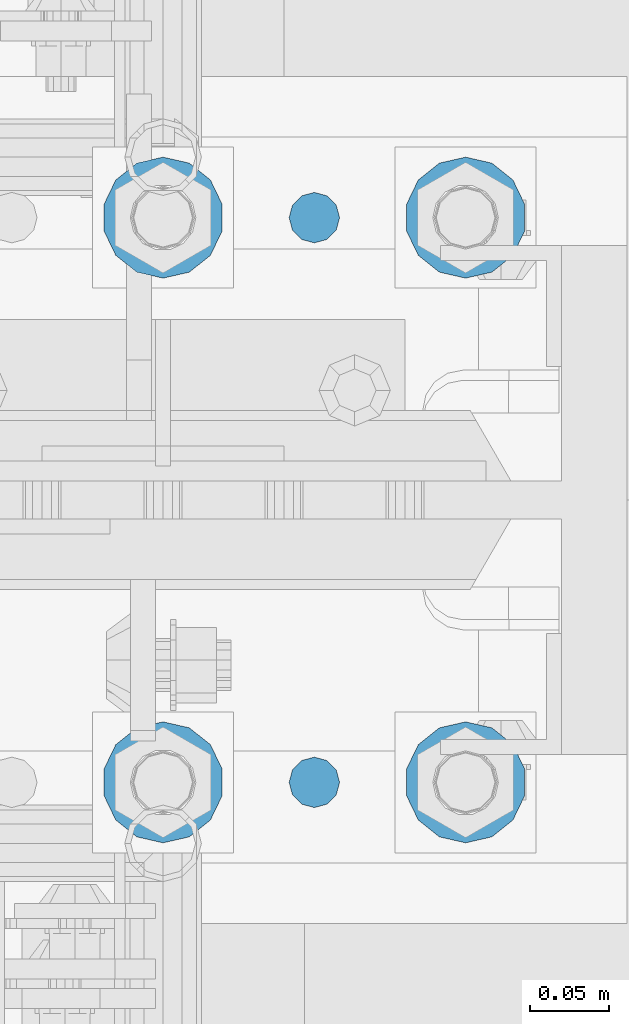
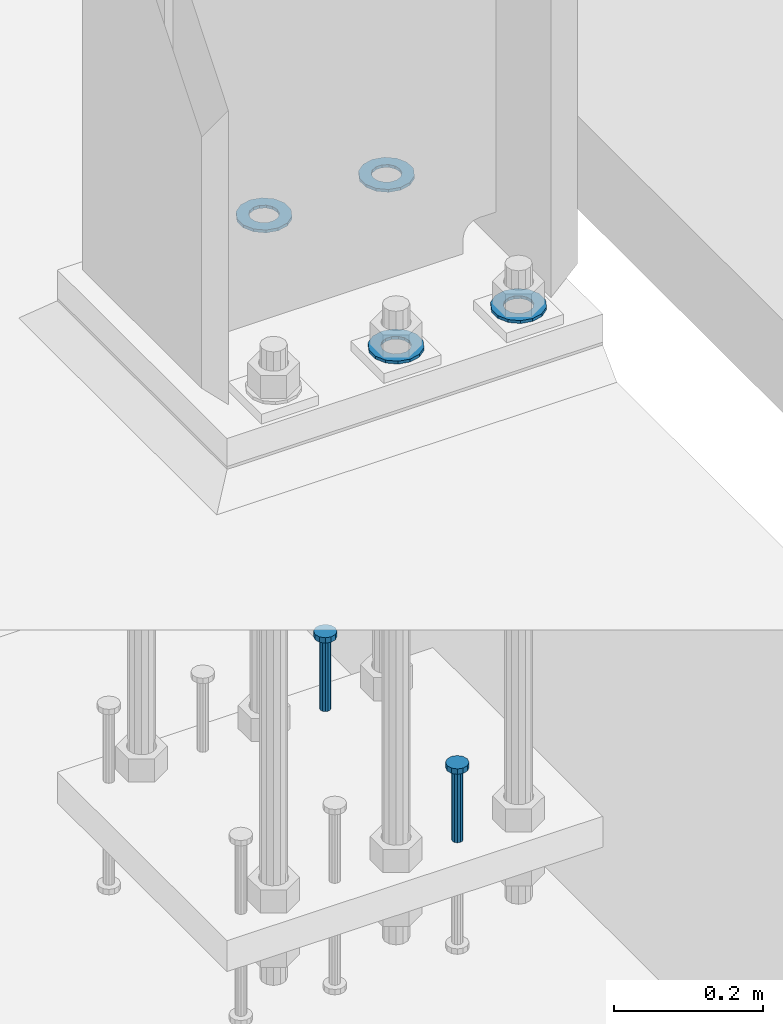
# One storey, part 832 of 1876: 6 columns, 1 element without a shape of its own.
"""IFC2X3 building model written with IfcOpenShell, lengths in millimetres."""

from ifc_helpers import new_model, si_unit, frame, origin_with_axes, place, context, subcontext, project, spatial, faceted_brep, material, type_object, element, aggregate, save


model = new_model("IFC2X3")

# Units and contexts
model_context = context("Model", 3, precision=1e-05, world=origin_with_axes())
body_context = subcontext(model_context, "Body", "Model", "MODEL_VIEW")
ifc_project = project(units=[si_unit("LENGTHUNIT", "METRE", prefix="MILLI"), si_unit("AREAUNIT", "SQUARE_METRE"), si_unit("VOLUMEUNIT", "CUBIC_METRE"), si_unit("MASSUNIT", "GRAM", prefix="KILO"), si_unit("TIMEUNIT", "SECOND"), si_unit("PLANEANGLEUNIT", "RADIAN"), si_unit("SOLIDANGLEUNIT", "STERADIAN"), si_unit("THERMODYNAMICTEMPERATUREUNIT", "DEGREE_CELSIUS"), si_unit("LUMINOUSINTENSITYUNIT", "LUMEN")], contexts=[model_context])

# Site, building, storey
site_placement = place(None, origin_with_axes())
site = spatial("IfcSite", under=ifc_project, at=site_placement, CompositionType="ELEMENT")
building_placement = place(site_placement, origin_with_axes())
building = spatial("IfcBuilding", under=site, at=building_placement, Name="Undefined", CompositionType="ELEMENT")
storey_placement = place(building_placement, origin_with_axes())
storey = spatial("IfcBuildingStorey", under=building, at=storey_placement, Name="Undefined", CompositionType="ELEMENT", Elevation=0.0)

# Assembly, columns
assembly_placement = place(storey_placement, origin_with_axes())
assembly = element("IfcElementAssembly", 1, at=assembly_placement, inside=storey, Name="TEMPLATE", AssemblyPlace="NOTDEFINED", PredefinedType="RIGID_FRAME")
ifc_material_1 = material(Name="STEEL/F436")
column_type_1 = type_object("IfcColumnType", Name="1-1/2_WASHER", PredefinedType="NOTDEFINED")
column_1_placement = place(assembly_placement, frame((7810.5, -4749.8, 109.5375), z_axis=(1.0, 0.0, 0.0), x_axis=(0.0, 0.0, -1.0)))
column_1 = element("IfcColumn", 2, at=column_1_placement, type_object=column_type_1, material=ifc_material_1, Name="WASHER", ObjectType="1-1/2_WASHER", context=body_context, shape_type="Brep", body=[
    faceted_brep([(0.0, -38.0999984741211, 0.0), (0.0, -34.3269124923136, -16.5309697983251), (4.7625, -34.3269124923136, -16.5309697983251), (4.7625, -38.0999984741211, 0.0), (0.0, -23.7549604994474, -29.787778289052), (4.7625, -23.7549604994474, -29.787778289052), (0.0, -8.4780472441962, -37.1447519665058), (4.7625, -8.4780472441962, -37.1447519665058), (0.0, 8.4780472441962, -37.1447519665058), (4.7625, 8.4780472441962, -37.1447519665058), (0.0, 23.7549604994474, -29.787778289052), (4.7625, 23.7549604994474, -29.787778289052), (0.0, 34.3269124923136, -16.5309697983251), (4.7625, 34.3269124923136, -16.5309697983251), (0.0, 38.0999984741211, 0.0), (4.7625, 38.0999984741211, 0.0), (0.0, 34.3269124923136, 16.5309697983251), (4.7625, 34.3269124923136, 16.5309697983251), (0.0, 23.7549604994474, 29.787778289052), (4.7625, 23.7549604994474, 29.787778289052), (0.0, 8.4780472441962, 37.1447519665058), (4.7625, 8.4780472441962, 37.1447519665058), (0.0, -8.4780472441962, 37.1447519665058), (4.7625, -8.4780472441962, 37.1447519665058), (0.0, -23.7549604994474, 29.787778289052), (4.7625, -23.7549604994474, 29.787778289052), (0.0, -34.3269124923136, 16.5309697983251), (4.7625, -34.3269124923136, 16.5309697983251), (0.0, 0.0, 20.6399993896484), (0.0, 8.95536011056538, 18.5959968835978), (4.7625, 8.95536011056538, 18.595996883598), (4.7625, 0.0, 20.6399993896484), (0.0, 16.1370013209489, 12.8688291298158), (4.7625, 16.1370013209489, 12.8688291298162), (0.0, 20.1225115123834, 4.59283194104228), (4.7625, 20.1225115123834, 4.59283194104222), (0.0, 20.1225115123834, -4.59283194104228), (4.7625, 20.1225115123834, -4.59283194104242), (0.0, 16.1370013209489, -12.8688291298167), (4.7625, 16.1370013209489, -12.8688291298163), (0.0, 8.95536011056538, -18.5959968835978), (4.7625, 8.95536011056538, -18.5959968835982), (0.0, 0.0, -20.6399993896484), (4.7625, 0.0, -20.6399993896484), (0.0, -8.95536011056538, -18.5959968835978), (4.7625, -8.95536011056538, -18.595996883598), (0.0, -16.1370013209489, -12.8688291298158), (4.7625, -16.1370013209489, -12.8688291298162), (0.0, -20.1225115123834, -4.59283194104228), (4.7625, -20.1225115123834, -4.59283194104222), (0.0, -20.1225115123834, 4.59283194104228), (4.7625, -20.1225115123834, 4.59283194104242), (0.0, -16.1370013209489, 12.8688291298167), (4.7625, -16.1370013209489, 12.8688291298163), (0.0, -8.95536011056538, 18.5959968835978), (4.7625, -8.95536011056538, 18.5959968835982)], [[[0, 1, 2, 3]], [[1, 4, 5, 2]], [[4, 6, 7, 5]], [[6, 8, 9, 7]], [[8, 10, 11, 9]], [[10, 12, 13, 11]], [[12, 14, 15, 13]], [[14, 16, 17, 15]], [[16, 18, 19, 17]], [[18, 20, 21, 19]], [[20, 22, 23, 21]], [[22, 24, 25, 23]], [[24, 26, 27, 25]], [[26, 0, 3, 27]], [[28, 29, 30, 31]], [[29, 32, 33, 30]], [[32, 34, 35, 33]], [[34, 36, 37, 35]], [[36, 38, 39, 37]], [[38, 40, 41, 39]], [[40, 42, 43, 41]], [[42, 44, 45, 43]], [[44, 46, 47, 45]], [[46, 48, 49, 47]], [[48, 50, 51, 49]], [[50, 52, 53, 51]], [[52, 54, 55, 53]], [[54, 28, 31, 55]], [[5, 7, 9, 11, 13, 15, 17, 19, 21, 23, 25, 27, 3, 2], [33, 35, 37, 39, 41, 43, 45, 47, 49, 51, 53, 55, 31, 30]], [[26, 24, 22, 20, 18, 16, 14, 12, 10, 8, 6, 4, 1, 0], [54, 52, 50, 48, 46, 44, 42, 40, 38, 36, 34, 32, 29, 28]]]),
])
column_2_placement = place(assembly_placement, frame((7810.5, -4394.2, 109.5375), z_axis=(-1.0, 0.0, 0.0), x_axis=(0.0, 0.0, -1.0)))
column_2 = element("IfcColumn", 3, at=column_2_placement, type_object=column_type_1, material=ifc_material_1, Name="WASHER", ObjectType="1-1/2_WASHER", context=body_context, shape_type="Brep", body=[
    faceted_brep([(0.0, -38.0999984741211, 0.0), (0.0, -34.3269124923136, -16.5309697983251), (4.7625, -34.3269124923136, -16.5309697983251), (4.7625, -38.0999984741211, 0.0), (0.0, -23.7549604994474, -29.787778289052), (4.7625, -23.7549604994474, -29.787778289052), (0.0, -8.4780472441962, -37.1447519665058), (4.7625, -8.4780472441962, -37.1447519665058), (0.0, 8.4780472441962, -37.1447519665058), (4.7625, 8.4780472441962, -37.1447519665058), (0.0, 23.7549604994474, -29.787778289052), (4.7625, 23.7549604994474, -29.787778289052), (0.0, 34.3269124923136, -16.5309697983251), (4.7625, 34.3269124923136, -16.5309697983251), (0.0, 38.0999984741211, 0.0), (4.7625, 38.0999984741211, 0.0), (0.0, 34.3269124923136, 16.5309697983251), (4.7625, 34.3269124923136, 16.5309697983251), (0.0, 23.7549604994474, 29.787778289052), (4.7625, 23.7549604994474, 29.787778289052), (0.0, 8.4780472441962, 37.1447519665058), (4.7625, 8.4780472441962, 37.1447519665058), (0.0, -8.4780472441962, 37.1447519665058), (4.7625, -8.4780472441962, 37.1447519665058), (0.0, -23.7549604994474, 29.787778289052), (4.7625, -23.7549604994474, 29.787778289052), (0.0, -34.3269124923136, 16.5309697983251), (4.7625, -34.3269124923136, 16.5309697983251), (0.0, 0.0, 20.6399993896484), (0.0, 8.95536011056538, 18.5959968835978), (4.7625, 8.95536011056538, 18.595996883598), (4.7625, 0.0, 20.6399993896484), (0.0, 16.1370013209489, 12.8688291298158), (4.7625, 16.1370013209489, 12.8688291298162), (0.0, 20.1225115123834, 4.59283194104228), (4.7625, 20.1225115123834, 4.59283194104222), (0.0, 20.1225115123834, -4.59283194104228), (4.7625, 20.1225115123834, -4.59283194104242), (0.0, 16.1370013209489, -12.8688291298167), (4.7625, 16.1370013209489, -12.8688291298163), (0.0, 8.95536011056538, -18.5959968835978), (4.7625, 8.95536011056538, -18.5959968835982), (0.0, 0.0, -20.6399993896484), (4.7625, 0.0, -20.6399993896484), (0.0, -8.95536011056538, -18.5959968835978), (4.7625, -8.95536011056538, -18.595996883598), (0.0, -16.1370013209489, -12.8688291298158), (4.7625, -16.1370013209489, -12.8688291298162), (0.0, -20.1225115123834, -4.59283194104228), (4.7625, -20.1225115123834, -4.59283194104222), (0.0, -20.1225115123834, 4.59283194104228), (4.7625, -20.1225115123834, 4.59283194104242), (0.0, -16.1370013209489, 12.8688291298167), (4.7625, -16.1370013209489, 12.8688291298163), (0.0, -8.95536011056538, 18.5959968835978), (4.7625, -8.95536011056538, 18.5959968835982)], [[[0, 1, 2, 3]], [[1, 4, 5, 2]], [[4, 6, 7, 5]], [[6, 8, 9, 7]], [[8, 10, 11, 9]], [[10, 12, 13, 11]], [[12, 14, 15, 13]], [[14, 16, 17, 15]], [[16, 18, 19, 17]], [[18, 20, 21, 19]], [[20, 22, 23, 21]], [[22, 24, 25, 23]], [[24, 26, 27, 25]], [[26, 0, 3, 27]], [[28, 29, 30, 31]], [[29, 32, 33, 30]], [[32, 34, 35, 33]], [[34, 36, 37, 35]], [[36, 38, 39, 37]], [[38, 40, 41, 39]], [[40, 42, 43, 41]], [[42, 44, 45, 43]], [[44, 46, 47, 45]], [[46, 48, 49, 47]], [[48, 50, 51, 49]], [[50, 52, 53, 51]], [[52, 54, 55, 53]], [[54, 28, 31, 55]], [[5, 7, 9, 11, 13, 15, 17, 19, 21, 23, 25, 27, 3, 2], [33, 35, 37, 39, 41, 43, 45, 47, 49, 51, 53, 55, 31, 30]], [[26, 24, 22, 20, 18, 16, 14, 12, 10, 8, 6, 4, 1, 0], [54, 52, 50, 48, 46, 44, 42, 40, 38, 36, 34, 32, 29, 28]]]),
])
column_3_placement = place(assembly_placement, frame((7620.0, -4749.8, 109.5375), z_axis=(1.0, 0.0, 0.0), x_axis=(0.0, 0.0, -1.0)))
column_3 = element("IfcColumn", 4, at=column_3_placement, type_object=column_type_1, material=ifc_material_1, Name="WASHER", ObjectType="1-1/2_WASHER", context=body_context, shape_type="Brep", body=[
    faceted_brep([(0.0, -38.0999984741211, 0.0), (0.0, -34.3269124923136, -16.5309697983251), (4.7625, -34.3269124923136, -16.5309697983251), (4.7625, -38.0999984741211, 0.0), (0.0, -23.7549604994474, -29.787778289052), (4.7625, -23.7549604994474, -29.787778289052), (0.0, -8.4780472441962, -37.1447519665058), (4.7625, -8.4780472441962, -37.1447519665058), (0.0, 8.4780472441962, -37.1447519665058), (4.7625, 8.4780472441962, -37.1447519665058), (0.0, 23.7549604994474, -29.787778289052), (4.7625, 23.7549604994474, -29.787778289052), (0.0, 34.3269124923136, -16.5309697983251), (4.7625, 34.3269124923136, -16.5309697983251), (0.0, 38.0999984741211, 0.0), (4.7625, 38.0999984741211, 0.0), (0.0, 34.3269124923136, 16.5309697983251), (4.7625, 34.3269124923136, 16.5309697983251), (0.0, 23.7549604994474, 29.787778289052), (4.7625, 23.7549604994474, 29.787778289052), (0.0, 8.4780472441962, 37.1447519665058), (4.7625, 8.4780472441962, 37.1447519665058), (0.0, -8.4780472441962, 37.1447519665058), (4.7625, -8.4780472441962, 37.1447519665058), (0.0, -23.7549604994474, 29.787778289052), (4.7625, -23.7549604994474, 29.787778289052), (0.0, -34.3269124923136, 16.5309697983251), (4.7625, -34.3269124923136, 16.5309697983251), (0.0, 0.0, 20.6399993896484), (0.0, 8.95536011056538, 18.5959968835978), (4.7625, 8.95536011056538, 18.595996883598), (4.7625, 0.0, 20.6399993896484), (0.0, 16.1370013209489, 12.8688291298158), (4.7625, 16.1370013209489, 12.8688291298162), (0.0, 20.1225115123834, 4.59283194104228), (4.7625, 20.1225115123834, 4.59283194104222), (0.0, 20.1225115123834, -4.59283194104228), (4.7625, 20.1225115123834, -4.59283194104242), (0.0, 16.1370013209489, -12.8688291298167), (4.7625, 16.1370013209489, -12.8688291298163), (0.0, 8.95536011056538, -18.5959968835978), (4.7625, 8.95536011056538, -18.5959968835982), (0.0, 0.0, -20.6399993896484), (4.7625, 0.0, -20.6399993896484), (0.0, -8.95536011056538, -18.5959968835978), (4.7625, -8.95536011056538, -18.595996883598), (0.0, -16.1370013209489, -12.8688291298158), (4.7625, -16.1370013209489, -12.8688291298162), (0.0, -20.1225115123834, -4.59283194104228), (4.7625, -20.1225115123834, -4.59283194104222), (0.0, -20.1225115123834, 4.59283194104228), (4.7625, -20.1225115123834, 4.59283194104242), (0.0, -16.1370013209489, 12.8688291298167), (4.7625, -16.1370013209489, 12.8688291298163), (0.0, -8.95536011056538, 18.5959968835978), (4.7625, -8.95536011056538, 18.5959968835982)], [[[0, 1, 2, 3]], [[1, 4, 5, 2]], [[4, 6, 7, 5]], [[6, 8, 9, 7]], [[8, 10, 11, 9]], [[10, 12, 13, 11]], [[12, 14, 15, 13]], [[14, 16, 17, 15]], [[16, 18, 19, 17]], [[18, 20, 21, 19]], [[20, 22, 23, 21]], [[22, 24, 25, 23]], [[24, 26, 27, 25]], [[26, 0, 3, 27]], [[28, 29, 30, 31]], [[29, 32, 33, 30]], [[32, 34, 35, 33]], [[34, 36, 37, 35]], [[36, 38, 39, 37]], [[38, 40, 41, 39]], [[40, 42, 43, 41]], [[42, 44, 45, 43]], [[44, 46, 47, 45]], [[46, 48, 49, 47]], [[48, 50, 51, 49]], [[50, 52, 53, 51]], [[52, 54, 55, 53]], [[54, 28, 31, 55]], [[5, 7, 9, 11, 13, 15, 17, 19, 21, 23, 25, 27, 3, 2], [33, 35, 37, 39, 41, 43, 45, 47, 49, 51, 53, 55, 31, 30]], [[26, 24, 22, 20, 18, 16, 14, 12, 10, 8, 6, 4, 1, 0], [54, 52, 50, 48, 46, 44, 42, 40, 38, 36, 34, 32, 29, 28]]]),
])
column_4_placement = place(assembly_placement, frame((7620.0, -4394.2, 109.5375), z_axis=(-1.0, 0.0, 0.0), x_axis=(0.0, 0.0, -1.0)))
column_4 = element("IfcColumn", 5, at=column_4_placement, type_object=column_type_1, material=ifc_material_1, Name="WASHER", ObjectType="1-1/2_WASHER", context=body_context, shape_type="Brep", body=[
    faceted_brep([(0.0, -38.0999984741211, 0.0), (0.0, -34.3269124923136, -16.5309697983251), (4.7625, -34.3269124923136, -16.5309697983251), (4.7625, -38.0999984741211, 0.0), (0.0, -23.7549604994474, -29.787778289052), (4.7625, -23.7549604994474, -29.787778289052), (0.0, -8.4780472441962, -37.1447519665058), (4.7625, -8.4780472441962, -37.1447519665058), (0.0, 8.4780472441962, -37.1447519665058), (4.7625, 8.4780472441962, -37.1447519665058), (0.0, 23.7549604994474, -29.787778289052), (4.7625, 23.7549604994474, -29.787778289052), (0.0, 34.3269124923136, -16.5309697983251), (4.7625, 34.3269124923136, -16.5309697983251), (0.0, 38.0999984741211, 0.0), (4.7625, 38.0999984741211, 0.0), (0.0, 34.3269124923136, 16.5309697983251), (4.7625, 34.3269124923136, 16.5309697983251), (0.0, 23.7549604994474, 29.787778289052), (4.7625, 23.7549604994474, 29.787778289052), (0.0, 8.4780472441962, 37.1447519665058), (4.7625, 8.4780472441962, 37.1447519665058), (0.0, -8.4780472441962, 37.1447519665058), (4.7625, -8.4780472441962, 37.1447519665058), (0.0, -23.7549604994474, 29.787778289052), (4.7625, -23.7549604994474, 29.787778289052), (0.0, -34.3269124923136, 16.5309697983251), (4.7625, -34.3269124923136, 16.5309697983251), (0.0, 0.0, 20.6399993896484), (0.0, 8.95536011056538, 18.5959968835978), (4.7625, 8.95536011056538, 18.595996883598), (4.7625, 0.0, 20.6399993896484), (0.0, 16.1370013209489, 12.8688291298158), (4.7625, 16.1370013209489, 12.8688291298162), (0.0, 20.1225115123834, 4.59283194104228), (4.7625, 20.1225115123834, 4.59283194104222), (0.0, 20.1225115123834, -4.59283194104228), (4.7625, 20.1225115123834, -4.59283194104242), (0.0, 16.1370013209489, -12.8688291298167), (4.7625, 16.1370013209489, -12.8688291298163), (0.0, 8.95536011056538, -18.5959968835978), (4.7625, 8.95536011056538, -18.5959968835982), (0.0, 0.0, -20.6399993896484), (4.7625, 0.0, -20.6399993896484), (0.0, -8.95536011056538, -18.5959968835978), (4.7625, -8.95536011056538, -18.595996883598), (0.0, -16.1370013209489, -12.8688291298158), (4.7625, -16.1370013209489, -12.8688291298162), (0.0, -20.1225115123834, -4.59283194104228), (4.7625, -20.1225115123834, -4.59283194104222), (0.0, -20.1225115123834, 4.59283194104228), (4.7625, -20.1225115123834, 4.59283194104242), (0.0, -16.1370013209489, 12.8688291298167), (4.7625, -16.1370013209489, 12.8688291298163), (0.0, -8.95536011056538, 18.5959968835978), (4.7625, -8.95536011056538, 18.5959968835982)], [[[0, 1, 2, 3]], [[1, 4, 5, 2]], [[4, 6, 7, 5]], [[6, 8, 9, 7]], [[8, 10, 11, 9]], [[10, 12, 13, 11]], [[12, 14, 15, 13]], [[14, 16, 17, 15]], [[16, 18, 19, 17]], [[18, 20, 21, 19]], [[20, 22, 23, 21]], [[22, 24, 25, 23]], [[24, 26, 27, 25]], [[26, 0, 3, 27]], [[28, 29, 30, 31]], [[29, 32, 33, 30]], [[32, 34, 35, 33]], [[34, 36, 37, 35]], [[36, 38, 39, 37]], [[38, 40, 41, 39]], [[40, 42, 43, 41]], [[42, 44, 45, 43]], [[44, 46, 47, 45]], [[46, 48, 49, 47]], [[48, 50, 51, 49]], [[50, 52, 53, 51]], [[52, 54, 55, 53]], [[54, 28, 31, 55]], [[5, 7, 9, 11, 13, 15, 17, 19, 21, 23, 25, 27, 3, 2], [33, 35, 37, 39, 41, 43, 45, 47, 49, 51, 53, 55, 31, 30]], [[26, 24, 22, 20, 18, 16, 14, 12, 10, 8, 6, 4, 1, 0], [54, 52, 50, 48, 46, 44, 42, 40, 38, 36, 34, 32, 29, 28]]]),
])
ifc_material_2 = material(Name="STEEL/A108")
column_type_2 = type_object("IfcColumnType", Name="5/8-DIA_HEADED ANCHOR STUD", PredefinedType="NOTDEFINED")
column_5_placement = place(assembly_placement, frame((7715.25, -4394.2, -736.6), z_axis=(1.0, 0.0, 0.0), x_axis=(0.0, 0.0, 1.0)))
column_5 = element("IfcColumn", 6, at=column_5_placement, type_object=column_type_2, material=ifc_material_2, Name="HEADED ANCHOR STUD", ObjectType="5/8-DIA_HEADED ANCHOR STUD", context=body_context, shape_type="Brep", body=[
    faceted_brep([(0.0, -7.94000005722046, 0.0), (0.0, -6.86999988555908, -3.97000002861023), (116.84, -6.86999988555908, -3.97000002861023), (116.84, -7.94000005722046, 0.0), (0.0, -3.97000002861023, -6.86999988555908), (116.84, -3.97000002861023, -6.86999988555908), (0.0, 0.0, -7.94000005722046), (116.84, 0.0, -7.94000005722046), (0.0, 3.97000002861023, -6.86999988555908), (116.84, 3.97000002861023, -6.86999988555908), (0.0, 6.86999988555908, -3.97000002861023), (116.84, 6.86999988555908, -3.97000002861023), (0.0, 7.94000005722046, 0.0), (116.84, 7.94000005722046, 0.0), (0.0, 6.86999988555908, 3.97000002861023), (116.84, 6.86999988555908, 3.97000002861023), (0.0, 3.97000002861023, 6.86999988555908), (116.84, 3.97000002861023, 6.86999988555908), (0.0, 0.0, 7.94000005722046), (116.84, 0.0, 7.94000005722046), (0.0, -3.97000002861023, 6.86999988555908), (116.84, -3.97000002861023, 6.86999988555908), (0.0, -6.86999988555908, 3.97000002861023), (116.84, -6.86999988555908, 3.97000002861023), (118.11, -13.75, -7.94000005722046), (118.11, -15.8800001144409, 0.0), (118.11, -7.94000005722046, -13.75), (118.11, 0.0, -15.8800001144409), (118.11, 7.94000005722046, -13.75), (118.11, 13.75, -7.94000005722046), (118.11, 15.8800001144409, 0.0), (118.11, 13.75, 7.94000005722046), (118.11, 7.94000005722046, 13.75), (118.11, 0.0, 15.8800001144409), (118.11, -7.94000005722046, 13.75), (118.11, -13.75, 7.94000005722046), (127.0, -13.75, -7.94000005722046), (127.0, -15.8800001144409, 0.0), (127.0, -7.94000005722046, -13.75), (127.0, 0.0, -15.8800001144409), (127.0, 7.94000005722046, -13.75), (127.0, 13.75, -7.94000005722046), (127.0, 15.8800001144409, 0.0), (127.0, 13.75, 7.94000005722046), (127.0, 7.94000005722046, 13.75), (127.0, 0.0, 15.8800001144409), (127.0, -7.94000005722046, 13.75), (127.0, -13.75, 7.94000005722046)], [[[0, 1, 2, 3]], [[1, 4, 5, 2]], [[4, 6, 7, 5]], [[6, 8, 9, 7]], [[8, 10, 11, 9]], [[10, 12, 13, 11]], [[12, 14, 15, 13]], [[14, 16, 17, 15]], [[16, 18, 19, 17]], [[18, 20, 21, 19]], [[20, 22, 23, 21]], [[22, 0, 3, 23]], [[22, 20, 18, 16, 14, 12, 10, 8, 6, 4, 1, 0]], [[3, 2, 24, 25]], [[2, 5, 26, 24]], [[5, 7, 27, 26]], [[7, 9, 28, 27]], [[9, 11, 29, 28]], [[11, 13, 30, 29]], [[13, 15, 31, 30]], [[15, 17, 32, 31]], [[17, 19, 33, 32]], [[19, 21, 34, 33]], [[21, 23, 35, 34]], [[23, 3, 25, 35]], [[25, 24, 36, 37]], [[24, 26, 38, 36]], [[26, 27, 39, 38]], [[27, 28, 40, 39]], [[28, 29, 41, 40]], [[29, 30, 42, 41]], [[30, 31, 43, 42]], [[31, 32, 44, 43]], [[32, 33, 45, 44]], [[33, 34, 46, 45]], [[34, 35, 47, 46]], [[35, 25, 37, 47]], [[38, 39, 40, 41, 42, 43, 44, 45, 46, 47, 37, 36]]]),
])
column_6_placement = place(assembly_placement, frame((7715.25, -4749.8, -736.6), z_axis=(1.0, 0.0, 0.0), x_axis=(0.0, 0.0, 1.0)))
column_6 = element("IfcColumn", 7, at=column_6_placement, type_object=column_type_2, material=ifc_material_2, Name="HEADED ANCHOR STUD", ObjectType="5/8-DIA_HEADED ANCHOR STUD", context=body_context, shape_type="Brep", body=[
    faceted_brep([(0.0, -7.94000005722046, 0.0), (0.0, -6.86999988555908, -3.97000002861023), (116.84, -6.86999988555908, -3.97000002861023), (116.84, -7.94000005722046, 0.0), (0.0, -3.97000002861023, -6.86999988555908), (116.84, -3.97000002861023, -6.86999988555908), (0.0, 0.0, -7.94000005722046), (116.84, 0.0, -7.94000005722046), (0.0, 3.97000002861023, -6.86999988555908), (116.84, 3.97000002861023, -6.86999988555908), (0.0, 6.86999988555908, -3.97000002861023), (116.84, 6.86999988555908, -3.97000002861023), (0.0, 7.94000005722046, 0.0), (116.84, 7.94000005722046, 0.0), (0.0, 6.86999988555908, 3.97000002861023), (116.84, 6.86999988555908, 3.97000002861023), (0.0, 3.97000002861023, 6.86999988555908), (116.84, 3.97000002861023, 6.86999988555908), (0.0, 0.0, 7.94000005722046), (116.84, 0.0, 7.94000005722046), (0.0, -3.97000002861023, 6.86999988555908), (116.84, -3.97000002861023, 6.86999988555908), (0.0, -6.86999988555908, 3.97000002861023), (116.84, -6.86999988555908, 3.97000002861023), (118.11, -13.75, -7.94000005722046), (118.11, -15.8800001144409, 0.0), (118.11, -7.94000005722046, -13.75), (118.11, 0.0, -15.8800001144409), (118.11, 7.94000005722046, -13.75), (118.11, 13.75, -7.94000005722046), (118.11, 15.8800001144409, 0.0), (118.11, 13.75, 7.94000005722046), (118.11, 7.94000005722046, 13.75), (118.11, 0.0, 15.8800001144409), (118.11, -7.94000005722046, 13.75), (118.11, -13.75, 7.94000005722046), (127.0, -13.75, -7.94000005722046), (127.0, -15.8800001144409, 0.0), (127.0, -7.94000005722046, -13.75), (127.0, 0.0, -15.8800001144409), (127.0, 7.94000005722046, -13.75), (127.0, 13.75, -7.94000005722046), (127.0, 15.8800001144409, 0.0), (127.0, 13.75, 7.94000005722046), (127.0, 7.94000005722046, 13.75), (127.0, 0.0, 15.8800001144409), (127.0, -7.94000005722046, 13.75), (127.0, -13.75, 7.94000005722046)], [[[0, 1, 2, 3]], [[1, 4, 5, 2]], [[4, 6, 7, 5]], [[6, 8, 9, 7]], [[8, 10, 11, 9]], [[10, 12, 13, 11]], [[12, 14, 15, 13]], [[14, 16, 17, 15]], [[16, 18, 19, 17]], [[18, 20, 21, 19]], [[20, 22, 23, 21]], [[22, 0, 3, 23]], [[22, 20, 18, 16, 14, 12, 10, 8, 6, 4, 1, 0]], [[3, 2, 24, 25]], [[2, 5, 26, 24]], [[5, 7, 27, 26]], [[7, 9, 28, 27]], [[9, 11, 29, 28]], [[11, 13, 30, 29]], [[13, 15, 31, 30]], [[15, 17, 32, 31]], [[17, 19, 33, 32]], [[19, 21, 34, 33]], [[21, 23, 35, 34]], [[23, 3, 25, 35]], [[25, 24, 36, 37]], [[24, 26, 38, 36]], [[26, 27, 39, 38]], [[27, 28, 40, 39]], [[28, 29, 41, 40]], [[29, 30, 42, 41]], [[30, 31, 43, 42]], [[31, 32, 44, 43]], [[32, 33, 45, 44]], [[33, 34, 46, 45]], [[34, 35, 47, 46]], [[35, 25, 37, 47]], [[38, 39, 40, 41, 42, 43, 44, 45, 46, 47, 37, 36]]]),
])
aggregate(assembly, [column_5, column_6, column_1, column_2, column_3, column_4])

save(model, "model.ifc")
